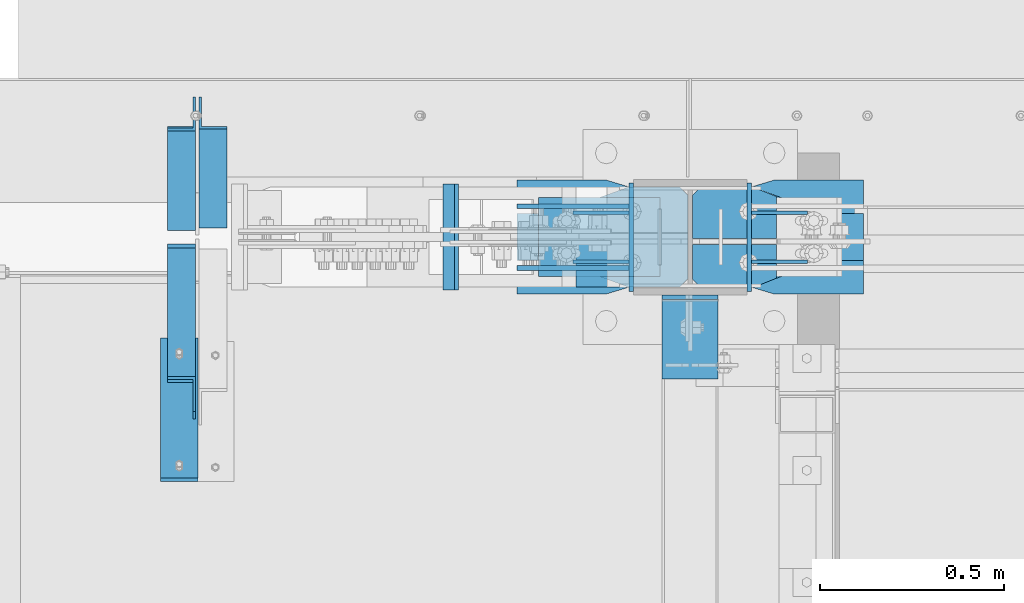
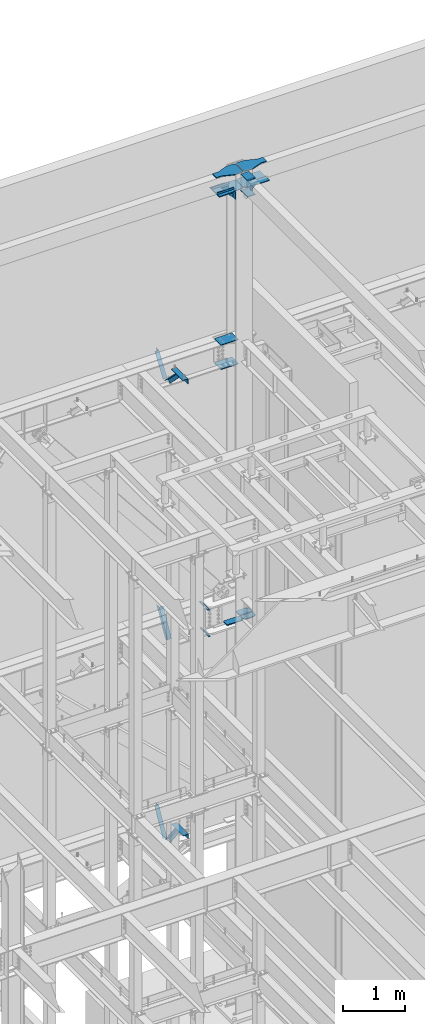
# One storey, part 926 of 1179: 23 beams, 5 members, 11 elements without a shape of their own.
"""IFC2X3 building model written with IfcOpenShell, lengths in millimetres."""

from ifc_helpers import new_model, si_unit, frame, origin_with_axes, place, context, subcontext, project, spatial, faceted_brep, material, type_object, element, aggregate, save


model = new_model("IFC2X3")

# Units and contexts
model_context = context("Model", 3, precision=1e-05, world=origin_with_axes())
body_context = subcontext(model_context, "Body", "Model", "MODEL_VIEW")
ifc_project = project(units=[si_unit("LENGTHUNIT", "METRE", prefix="MILLI"), si_unit("AREAUNIT", "SQUARE_METRE"), si_unit("VOLUMEUNIT", "CUBIC_METRE"), si_unit("MASSUNIT", "GRAM", prefix="KILO"), si_unit("TIMEUNIT", "SECOND"), si_unit("PLANEANGLEUNIT", "RADIAN"), si_unit("SOLIDANGLEUNIT", "STERADIAN"), si_unit("THERMODYNAMICTEMPERATUREUNIT", "DEGREE_CELSIUS"), si_unit("LUMINOUSINTENSITYUNIT", "LUMEN")], contexts=[model_context])

# Site, building, storey
site_placement = place(None, origin_with_axes())
site = spatial("IfcSite", under=ifc_project, at=site_placement, CompositionType="ELEMENT")
building_placement = place(site_placement, origin_with_axes())
building = spatial("IfcBuilding", under=site, at=building_placement, Name="Undefined", CompositionType="ELEMENT")
storey_placement = place(building_placement, origin_with_axes())
storey = spatial("IfcBuildingStorey", under=building, at=storey_placement, Name="Undefined", CompositionType="ELEMENT", Elevation=0.0)

# Assembly, member
assembly_1_placement = place(storey_placement, origin_with_axes())
assembly_1 = element("IfcElementAssembly", 1, at=assembly_1_placement, inside=storey, Name="ANGLE", AssemblyPlace="NOTDEFINED", PredefinedType="RIGID_FRAME")
ifc_material_1 = material(Name="STEEL/A36")
member_type = type_object("IfcMemberType", Name="L3X3X1/4", PredefinedType="NOTDEFINED")
member_1_placement = place(assembly_1_placement, frame((15160.625, 41656.0, 8227.31342088179), z_axis=(0.0, 0.872675718014636, -0.488300206008189), x_axis=(0.0, -0.48830020600819, -0.872675718014636)))
member_1 = element("IfcMember", 2, at=member_1_placement, type_object=member_type, material=ifc_material_1, Name="ANGLE", ObjectType="L3X3X1/4", context=body_context, shape_type="Brep", body=[
    faceted_brep([(266.09845322503, 38.1000000000004, -38.1000000001477), (223.461222774196, 38.1000000000004, 38.0999999997293), (818.212094408347, 38.1000000000004, 38.0999999992346), (818.21209440822, 38.1000000000004, -38.100000000617), (223.461222774196, 31.75, 38.0999999997293), (818.212094408347, 31.75, 38.0999999992346), (262.545350687458, 31.75, -31.7500000001601), (818.212094408227, 31.75, -31.7500000006257), (262.545350687458, -38.1000000000004, -31.7500000001601), (818.212094408227, -38.1000000000004, -31.7500000006257), (266.09845322503, -38.1000000000004, -38.1000000001477), (818.21209440822, -38.1000000000004, -38.100000000617)], [[[0, 1, 2, 3]], [[1, 4, 5, 2]], [[4, 6, 7, 5]], [[6, 8, 9, 7]], [[8, 10, 11, 9]], [[10, 0, 3, 11]], [[5, 7, 9, 11, 3, 2]], [[10, 8, 6, 4, 1, 0]]]),
])
aggregate(assembly_1, [member_1])

assembly_2_placement = place(storey_placement, origin_with_axes())
assembly_2 = element("IfcElementAssembly", 3, at=assembly_2_placement, inside=storey, Name="ANGLE", AssemblyPlace="NOTDEFINED", PredefinedType="RIGID_FRAME")
member_2_placement = place(assembly_2_placement, frame((15074.90025, 40722.5021746856, 4156.39103856133), z_axis=(0.0, -0.797785167426298, -0.602941810322185), x_axis=(0.0, 0.602941810322187, -0.797785167426297)))
member_2 = element("IfcMember", 4, at=member_2_placement, type_object=member_type, material=ifc_material_1, Name="ANGLE", ObjectType="L3X3X1/4", context=body_context, shape_type="Brep", body=[
    faceted_brep([(110.776215380578, 38.1000000000004, -38.1000000000058), (53.1865686658894, 38.1000000000004, 38.1000000001659), (690.351875241478, 38.1000000000004, 38.1000000007261), (690.351875241598, 38.1000000000004, -38.0999999994892), (53.1865686658894, 31.75, 38.1000000001659), (690.351875241478, 31.75, 38.1000000007261), (105.977078154352, 31.75, -31.7499999999927), (690.351875241595, 31.75, -31.7499999994689), (105.977078154352, -38.1000000000004, -31.7499999999927), (690.351875241595, -38.1000000000004, -31.7499999994689), (110.776215380578, -38.1000000000004, -38.1000000000058), (690.351875241598, -38.1000000000004, -38.0999999994892)], [[[0, 1, 2, 3]], [[1, 4, 5, 2]], [[4, 6, 7, 5]], [[6, 8, 9, 7]], [[8, 10, 11, 9]], [[10, 0, 3, 11]], [[5, 7, 9, 11, 3, 2]], [[10, 8, 6, 4, 1, 0]]]),
])
aggregate(assembly_2, [member_2])

assembly_3_placement = place(storey_placement, origin_with_axes())
assembly_3 = element("IfcElementAssembly", 5, at=assembly_3_placement, inside=storey, Name="ANGLE", AssemblyPlace="NOTDEFINED", PredefinedType="RIGID_FRAME")
member_3_placement = place(assembly_3_placement, frame((15074.90025, 41256.8364339201, 3601.33927004389), z_axis=(0.0, 0.873306509536275, -0.487171161299155), x_axis=(0.0, 0.487171161299156, 0.873306509536275)))
member_3 = element("IfcMember", 6, at=member_3_placement, type_object=member_type, material=ifc_material_1, Name="ANGLE", ObjectType="L3X3X1/4", context=body_context, shape_type="Brep", body=[
    faceted_brep([(0.0, 38.0999999999985, -38.0999999999999), (0.0, 38.0999999999985, 38.0999999999999), (594.661720177039, 38.1000000000004, 38.1000000011991), (552.153801037723, 38.1000000000004, -38.0999999989144), (0.0, 31.75, 38.1000000000004), (594.661720177039, 31.75, 38.1000000011991), (0.0, 31.75, -31.75), (555.696127632669, 31.75, -31.7499999988941), (0.0, -38.0999999999985, -31.75), (555.696127632669, -38.1000000000004, -31.7499999988941), (0.0, -38.0999999999985, -38.0999999999999), (552.153801037723, -38.1000000000004, -38.0999999989144)], [[[0, 1, 2, 3]], [[1, 4, 5, 2]], [[4, 6, 7, 5]], [[6, 8, 9, 7]], [[8, 10, 11, 9]], [[10, 0, 3, 11]], [[5, 7, 9, 11, 3, 2]], [[10, 8, 6, 4, 1, 0]]]),
])
aggregate(assembly_3, [member_3])

assembly_4_placement = place(storey_placement, origin_with_axes())
assembly_4 = element("IfcElementAssembly", 7, at=assembly_4_placement, inside=storey, Name="ANGLE", AssemblyPlace="NOTDEFINED", PredefinedType="RIGID_FRAME")
member_4_placement = place(assembly_4_placement, frame((15074.9, 40704.7386537875, 13150.1502196524), z_axis=(0.0, -0.706388288025418, -0.707824545025474), x_axis=(0.0, 0.707824545025473, -0.706388288025419)))
member_4 = element("IfcMember", 8, at=member_4_placement, type_object=member_type, material=ifc_material_1, Name="ANGLE", ObjectType="L3X3X1/4", context=body_context, shape_type="Brep", body=[
    faceted_brep([(634.184990526992, 31.75, 38.0999999999767), (634.184990526996, 31.75, -31.7499999999636), (634.184990526996, -38.0999999999985, -31.7499999999636), (634.184990526996, -38.0999999999985, -38.0999999999549), (634.184990526996, 38.0999999999985, -38.0999999999549), (634.184990526992, 38.0999999999985, 38.0999999999767), (113.596638248473, -38.0999999999985, -38.0999999999549), (113.596638248473, 38.0999999999985, -38.0999999999549), (37.2417053522113, 38.0999999999985, 38.0999999999694), (37.2417053522113, 31.75, 38.0999999999694), (107.233727173789, 31.75, -31.7499999999709), (107.233727173789, -38.0999999999985, -31.7499999999709)], [[[0, 1, 2, 3, 4, 5]], [[4, 3, 6, 7]], [[5, 4, 7, 8]], [[0, 5, 8, 9]], [[1, 0, 9, 10]], [[2, 1, 10, 11]], [[3, 2, 11, 6]], [[10, 9, 8, 7, 6, 11]]]),
])
aggregate(assembly_4, [member_4])

assembly_5_placement = place(storey_placement, origin_with_axes())
assembly_5 = element("IfcElementAssembly", 9, at=assembly_5_placement, inside=storey, Name="ANGLE", AssemblyPlace="NOTDEFINED", PredefinedType="RIGID_FRAME")
member_5_placement = place(assembly_5_placement, frame((15074.9, 41248.3636551321, 12707.4244380128), z_axis=(0.0, 0.821716663099518, -0.569896241069015), x_axis=(0.0, 0.569896241069016, 0.821716663099518)))
member_5 = element("IfcMember", 10, at=member_5_placement, type_object=member_type, material=ifc_material_1, Name="ANGLE", ObjectType="L3X3X1/4", context=body_context, shape_type="Brep", body=[
    faceted_brep([(0.0, -38.0999999999985, -38.0999999999999), (0.0, -38.0999999999985, -31.75), (0.0, 31.75, -31.75), (0.0, 31.75, 38.1000000000004), (0.0, 38.0999999999985, 38.0999999999999), (0.0, 38.0999999999985, -38.0999999999999), (527.418547333735, 31.75, 38.0999999993364), (527.418547333735, 38.1000000000004, 38.0999999993364), (474.570533511644, 38.1000000000004, -38.1000000006607), (474.570533511644, -38.1000000000004, -38.1000000006607), (478.974534663488, -38.1000000000004, -31.7500000006621), (478.974534663488, 31.75, -31.7500000006621)], [[[0, 1, 2, 3, 4, 5]], [[4, 3, 6, 7]], [[5, 4, 7, 8]], [[0, 5, 8, 9]], [[1, 0, 9, 10]], [[2, 1, 10, 11]], [[3, 2, 11, 6]], [[10, 9, 8, 7, 6, 11]]]),
])
aggregate(assembly_5, [member_5])

# Assembly, beams
assembly_6_placement = place(storey_placement, origin_with_axes())
assembly_6 = element("IfcElementAssembly", 11, at=assembly_6_placement, inside=storey, Name="BEAM", AssemblyPlace="NOTDEFINED", PredefinedType="RIGID_FRAME")
ifc_material_2 = material(Name="STEEL/A572-GR.50")
beam_type_1 = type_object("IfcBeamType", PredefinedType="NOTDEFINED")
beam_1_placement = place(assembly_6_placement, frame((15828.6656815561, 41198.7999633791, 7459.6625), z_axis=(0.0, 1.0, 0.0), x_axis=(-1.0, 0.0, 0.0)))
beam_1 = element("IfcBeam", 12, at=beam_1_placement, type_object=beam_type_1, material=ifc_material_2, Name="PLATE", context=body_context, shape_type="Brep", body=[
    faceted_brep([(0.0, 4.76249999999982, -144.462500000001), (0.0, 4.76249999999982, 144.462500000001), (31.7500000000036, 4.76249999999982, 144.462500000001), (31.7500000000036, 4.76249999999982, -144.462500000001), (0.0, -4.76249999999982, 144.462500000001), (31.7500000000036, -4.76249999999982, 144.462500000001), (0.0, -4.76249999999982, -144.462500000001), (31.7500000000036, -4.76249999999982, -144.462500000001)], [[[0, 1, 2, 3]], [[1, 4, 5, 2]], [[4, 6, 7, 5]], [[6, 0, 3, 7]], [[5, 7, 3, 2]], [[6, 4, 1, 0]]]),
])
beam_2_placement = place(assembly_6_placement, frame((15817.5535981227, 41198.7999633791, 7984.72549025941), z_axis=(0.0, 1.0, 0.0), x_axis=(-1.0, 0.0, 0.0)))
beam_2 = element("IfcBeam", 13, at=beam_2_placement, type_object=beam_type_1, material=ifc_material_2, Name="PLATE", context=body_context, shape_type="Brep", body=[
    faceted_brep([(0.0, 4.76249999999982, -144.462500000001), (0.0, 4.76249999999982, 144.462500000001), (31.7500000000036, 4.76249999999982, 144.462500000001), (31.7500000000036, 4.76249999999982, -144.462500000001), (0.0, -4.76249999999982, 144.462500000001), (31.7500000000036, -4.76249999999982, 144.462500000001), (0.0, -4.76249999999982, -144.462500000001), (31.7500000000036, -4.76249999999982, -144.462500000001)], [[[0, 1, 2, 3]], [[1, 4, 5, 2]], [[4, 6, 7, 5]], [[6, 0, 3, 7]], [[5, 7, 3, 2]], [[6, 4, 1, 0]]]),
])
aggregate(assembly_6, [beam_1, beam_2])

assembly_7_placement = place(storey_placement, origin_with_axes())
assembly_7 = element("IfcElementAssembly", 14, at=assembly_7_placement, inside=storey, Name="COLUMN", AssemblyPlace="NOTDEFINED", PredefinedType="RIGID_FRAME")
beam_type_2 = type_object("IfcBeamType", PredefinedType="NOTDEFINED")
beam_3_placement = place(assembly_7_placement, frame((16298.8624999594, 41346.4375, 16030.575), z_axis=(0.0, 0.0, 1.0), x_axis=(0.0, -1.0, 0.0)))
beam_3 = element("IfcBeam", 15, at=beam_3_placement, type_object=beam_type_2, material=ifc_material_1, Name="PLATE", context=body_context, shape_type="Brep", body=[
    faceted_brep([(-7.27595761418343e-12, 6.35000000000036, -76.1999999999971), (0.0, 6.35000000000036, 76.2000000000044), (295.274999999994, 6.34999999999854, 76.2000000000007), (295.274999999994, 6.34999999999854, -76.2000000000007), (0.0, -6.35000000000036, 76.2000000000044), (295.274999999994, -6.34999999999854, 76.2000000000007), (7.27595761418343e-12, -6.35000000000036, -76.1999999999971), (295.274999999994, -6.34999999999854, -76.2000000000007)], [[[0, 1, 2, 3]], [[1, 4, 5, 2]], [[4, 6, 7, 5]], [[6, 0, 3, 7]], [[5, 7, 3, 2]], [[6, 4, 1, 0]]]),
])
beam_4_placement = place(assembly_7_placement, frame((16619.5375, 41051.1625, 16030.575), z_axis=(0.0, 0.0, 1.0), x_axis=(0.0, 1.0, 0.0)))
beam_4 = element("IfcBeam", 16, at=beam_4_placement, type_object=beam_type_2, material=ifc_material_1, Name="PLATE", context=body_context, shape_type="Brep", body=[
    faceted_brep([(-7.27595761418343e-12, 6.35000000000036, -76.1999999999971), (0.0, 6.35000000000036, 76.2000000000044), (295.274999999994, 6.34999999999854, 76.2000000000007), (295.274999999994, 6.34999999999854, -76.2000000000007), (0.0, -6.35000000000036, 76.2000000000044), (295.274999999994, -6.34999999999854, 76.2000000000007), (7.27595761418343e-12, -6.35000000000036, -76.1999999999971), (295.274999999994, -6.34999999999854, -76.2000000000007)], [[[0, 1, 2, 3]], [[1, 4, 5, 2]], [[4, 6, 7, 5]], [[6, 0, 3, 7]], [[5, 7, 3, 2]], [[6, 4, 1, 0]]]),
])
beam_5_placement = place(assembly_7_placement, frame((16459.2, 40813.0375061035, 16116.3), z_axis=(1.0, 0.0, 0.0), x_axis=(0.0, 1.0, 0.0)))
beam_5 = element("IfcBeam", 17, at=beam_5_placement, type_object=beam_type_2, material=ifc_material_1, Name="PLATE", context=body_context, shape_type="Brep", body=[
    faceted_brep([(215.900000000001, 6.35000000000036, 76.2000000000007), (228.599999999999, -6.35000000000036, 76.2000000000007), (228.599999999999, -6.35000000000036, -76.2000000000007), (215.900000000001, 6.35000000000036, -76.2000000000007), (-7.27595761418343e-12, 6.35000000000036, -76.1999999999971), (0.0, 6.35000000000036, 76.2000000000044), (0.0, -6.35000000000036, 76.2000000000044), (7.27595761418343e-12, -6.35000000000036, -76.1999999999971)], [[[0, 1, 2, 3]], [[4, 5, 0, 3]], [[5, 6, 1, 0]], [[6, 7, 2, 1]], [[7, 4, 3, 2]], [[7, 6, 5, 4]]]),
])
beam_6_placement = place(assembly_7_placement, frame((16459.2, 40813.0375059853, 16435.3875), z_axis=(1.0, 0.0, 0.0), x_axis=(0.0, 1.0, 0.0)))
beam_6 = element("IfcBeam", 18, at=beam_6_placement, type_object=beam_type_2, material=ifc_material_1, Name="PLATE", context=body_context, shape_type="Brep", body=[
    faceted_brep([(215.900000000001, 6.35000000000036, 76.2000000000007), (228.599999999999, -6.35000000000036, 76.2000000000007), (228.599999999999, -6.35000000000036, -76.2000000000007), (215.900000000001, 6.35000000000036, -76.2000000000007), (-7.27595761418343e-12, 6.35000000000036, -76.1999999999971), (0.0, 6.35000000000036, 76.2000000000044), (0.0, -6.35000000000036, 76.2000000000044), (7.27595761418343e-12, -6.35000000000036, -76.1999999999971)], [[[0, 1, 2, 3]], [[4, 5, 0, 3]], [[5, 6, 1, 0]], [[6, 7, 2, 1]], [[7, 4, 3, 2]], [[7, 6, 5, 4]]]),
])
beam_type_3 = type_object("IfcBeamType", PredefinedType="NOTDEFINED")
beam_7_placement = place(assembly_7_placement, frame((16376.8467347126, 41198.8000000024, 12646.02499997), z_axis=(0.0, -1.0, 0.0), x_axis=(-1.0, 0.0, 0.0)))
beam_7 = element("IfcBeam", 19, at=beam_7_placement, type_object=beam_type_3, material=ifc_material_2, Name="PLATE", context=body_context, shape_type="Brep", body=[
    faceted_brep([(0.0, 6.35000000000036, -107.949999999997), (0.0, 6.35000000000036, 107.949999999997), (330.200000043667, 6.35000000000036, 107.949999999997), (330.200000043667, 6.35000000000036, -107.949999999997), (0.0, -6.35000000000036, 107.949999999997), (330.200000043667, -6.35000000000036, 107.949999999997), (0.0, -6.35000000000036, -107.949999999997), (330.200000043667, -6.35000000000036, -107.949999999997)], [[[0, 1, 2, 3]], [[1, 4, 5, 2]], [[4, 6, 7, 5]], [[6, 0, 3, 7]], [[5, 7, 3, 2]], [[6, 4, 1, 0]]]),
])
beam_8_placement = place(assembly_7_placement, frame((16376.8467347052, 41198.8000000024, 13125.44999997), z_axis=(0.0, -1.0, 0.0), x_axis=(-1.0, 0.0, 0.0)))
beam_8 = element("IfcBeam", 20, at=beam_8_placement, type_object=beam_type_3, material=ifc_material_2, Name="PLATE", context=body_context, shape_type="Brep", body=[
    faceted_brep([(0.0, 6.35000000000036, -107.949999999997), (0.0, 6.35000000000036, 107.949999999997), (330.200000043667, 6.35000000000036, 107.949999999997), (330.200000043667, 6.35000000000036, -107.949999999997), (0.0, -6.35000000000036, 107.949999999997), (330.200000043667, -6.35000000000036, 107.949999999997), (0.0, -6.35000000000036, -107.949999999997), (330.200000043667, -6.35000000000036, -107.949999999997)], [[[0, 1, 2, 3]], [[1, 4, 5, 2]], [[4, 6, 7, 5]], [[6, 0, 3, 7]], [[5, 7, 3, 2]], [[6, 4, 1, 0]]]),
])
beam_type_4 = type_object("IfcBeamType", PredefinedType="NOTDEFINED")
beam_9_placement = place(assembly_7_placement, frame((16148.0499999994, 41125.775, 7556.5), z_axis=(0.0, -1.0, 0.0), x_axis=(1.0, 0.0, 0.0)))
beam_9 = element("IfcBeam", 21, at=beam_9_placement, type_object=beam_type_4, material=ifc_material_2, Name="PLATE", context=body_context, shape_type="Brep", body=[
    faceted_brep([(304.800000000001, 9.52499999999964, 41.2750000000015), (282.575000000003, 9.52499999999964, 63.5), (282.575000000003, -9.52499999999964, 63.5), (304.800000000001, -9.52499999999964, 41.2750000000015), (304.800000000001, 9.52499999999964, -63.5), (0.0, 9.52500000000146, -63.5), (0.0, 9.52500000000146, 63.5), (0.0, -9.52500000000146, 63.5), (0.0, -9.52500000000146, -63.5), (304.800000000001, -9.52499999999964, -63.5)], [[[0, 1, 2, 3]], [[4, 5, 6, 1, 0]], [[6, 7, 2, 1]], [[7, 8, 9, 3, 2]], [[8, 5, 4, 9]], [[9, 4, 0, 3]], [[8, 7, 6, 5]]]),
])

# Assembly, beam
assembly_8_placement = place(storey_placement, origin_with_axes())
assembly_8 = element("IfcElementAssembly", 22, at=assembly_8_placement, inside=storey, Name="ANGLE", AssemblyPlace="NOTDEFINED", PredefinedType="RIGID_FRAME")
beam_type_5 = type_object("IfcBeamType", Name="L4X4X1/4", PredefinedType="NOTDEFINED")
beam_10_placement = place(assembly_8_placement, frame((15068.5502499985, 40914.6373750007, 4051.30000000071), z_axis=(-1.0, 0.0, 0.0), x_axis=(0.0, -1.0, 0.0)))
beam_10 = element("IfcBeam", 23, at=beam_10_placement, type_object=beam_type_5, material=ifc_material_1, Name="ANGLE", ObjectType="L4X4X1/4", context=body_context, shape_type="Brep", body=[
    faceted_brep([(1.90993887372315e-11, 50.8000000000002, -50.8000000000002), (1.90993887372315e-11, 50.8000000000002, 50.8000000000002), (381.0, 50.8000000000002, 50.7999999999993), (381.0, 50.8000000000002, -50.7999999999993), (0.0, 44.4500000000007, 50.8000000000002), (381.0, 44.4499999999998, 50.7999999999993), (0.0, 44.4500000000007, -44.4499999999998), (381.0, 44.4499999999998, -44.4500000000007), (0.0, -50.7999999999993, -44.4499999999998), (381.0, -50.8000000000002, -44.4500000000007), (-1.81898940354586e-11, -50.7999999999997, -50.8000000000002), (381.0, -50.8000000000002, -50.7999999999993)], [[[0, 1, 2, 3]], [[1, 4, 5, 2]], [[4, 6, 7, 5]], [[6, 8, 9, 7]], [[8, 10, 11, 9]], [[10, 0, 3, 11]], [[5, 7, 9, 11, 3, 2]], [[10, 8, 6, 4, 1, 0]]]),
])
aggregate(assembly_8, [beam_10])

assembly_9_placement = place(storey_placement, origin_with_axes())
assembly_9 = element("IfcElementAssembly", 24, at=assembly_9_placement, inside=storey, Name="ANGLE", AssemblyPlace="NOTDEFINED", PredefinedType="RIGID_FRAME")
beam_11_placement = place(assembly_9_placement, frame((15068.549999998, 40924.1624999531, 13068.3), z_axis=(-1.0, 0.0, 0.0), x_axis=(0.0, -1.0, 0.0)))
beam_11 = element("IfcBeam", 25, at=beam_11_placement, type_object=beam_type_5, material=ifc_material_1, Name="ANGLE", ObjectType="L4X4X1/4", context=body_context, shape_type="Brep", body=[
    faceted_brep([(1.90993887372315e-11, 50.8000000000002, -50.8000000000002), (1.90993887372315e-11, 50.8000000000002, 50.8000000000002), (381.0, 50.8000000000002, 50.7999999999993), (381.0, 50.8000000000002, -50.7999999999993), (0.0, 44.4500000000007, 50.8000000000002), (381.0, 44.4499999999998, 50.7999999999993), (0.0, 44.4500000000007, -44.4499999999998), (381.0, 44.4499999999998, -44.4500000000007), (0.0, -50.7999999999993, -44.4499999999998), (381.0, -50.8000000000002, -44.4500000000007), (-1.81898940354586e-11, -50.7999999999997, -50.8000000000002), (381.0, -50.8000000000002, -50.7999999999993)], [[[0, 1, 2, 3]], [[1, 4, 5, 2]], [[4, 6, 7, 5]], [[6, 8, 9, 7]], [[8, 10, 11, 9]], [[10, 0, 3, 11]], [[5, 7, 9, 11, 3, 2]], [[10, 8, 6, 4, 1, 0]]]),
])
aggregate(assembly_9, [beam_11])

# Beam
beam_type_6 = type_object("IfcBeamType", PredefinedType="NOTDEFINED")
beam_12_placement = place(assembly_7_placement, frame((15987.7124999797, 41282.9375, 16141.7), z_axis=(0.0, 0.0, 1.0), x_axis=(1.0, 0.0, 0.0)))
beam_12 = element("IfcBeam", 26, at=beam_12_placement, type_object=beam_type_6, material=ifc_material_1, Name="PLATE", context=body_context, shape_type="Brep", body=[
    faceted_brep([(0.0, 6.34999999999854, -19.0499999999993), (0.0, 6.35000000000036, 19.0499999999993), (317.5, 6.34999999999854, 19.0499999999993), (317.5, 6.34999999999854, -19.0499999999993), (0.0, -6.35000000000036, 19.0499999999993), (317.5, -6.34999999999854, 19.0499999999993), (0.0, -6.34999999999854, -19.0499999999993), (317.5, -6.34999999999854, -19.0499999999993)], [[[0, 1, 2, 3]], [[1, 4, 5, 2]], [[4, 6, 7, 5]], [[6, 0, 3, 7]], [[5, 7, 3, 2]], [[6, 4, 1, 0]]]),
])

beam_13_placement = place(assembly_7_placement, frame((15987.7124999797, 41114.6625, 16141.7), z_axis=(0.0, 0.0, 1.0), x_axis=(1.0, 0.0, 0.0)))
beam_13 = element("IfcBeam", 27, at=beam_13_placement, type_object=beam_type_6, material=ifc_material_1, Name="PLATE", context=body_context, shape_type="Brep", body=[
    faceted_brep([(0.0, 6.34999999999854, -19.0499999999993), (0.0, 6.35000000000036, 19.0499999999993), (317.5, 6.34999999999854, 19.0499999999993), (317.5, 6.34999999999854, -19.0499999999993), (0.0, -6.35000000000036, 19.0499999999993), (317.5, -6.34999999999854, 19.0499999999993), (0.0, -6.34999999999854, -19.0499999999993), (317.5, -6.34999999999854, -19.0499999999993)], [[[0, 1, 2, 3]], [[1, 4, 5, 2]], [[4, 6, 7, 5]], [[6, 0, 3, 7]], [[5, 7, 3, 2]], [[6, 4, 1, 0]]]),
])

beam_type_7 = type_object("IfcBeamType", PredefinedType="NOTDEFINED")
beam_14_placement = place(assembly_7_placement, frame((16140.1124999594, 41265.475, 16030.575), z_axis=(0.0, 0.0, 1.0), x_axis=(1.0, 0.0, 0.0)))
beam_14 = element("IfcBeam", 28, at=beam_14_placement, type_object=beam_type_7, material=ifc_material_1, Name="PLATE", context=body_context, shape_type="Brep", body=[
    faceted_brep([(152.4, -4.76249999999709, 76.2), (152.4, -4.76249999999709, -76.2), (152.4, 4.76249999999709, -76.2), (152.4, 4.76249999999709, 76.2), (0.0, 4.76249999999982, 76.1999999999971), (0.0, -4.76249999999982, 76.1999999999971)], [[[0, 1, 2, 3]], [[3, 2, 4]], [[4, 5, 0, 3]], [[0, 5, 1]], [[4, 2, 1, 5]]]),
])

beam_15_placement = place(assembly_7_placement, frame((16140.1124999594, 41132.125, 16030.575), z_axis=(0.0, 0.0, 1.0), x_axis=(1.0, 0.0, 0.0)))
beam_15 = element("IfcBeam", 29, at=beam_15_placement, type_object=beam_type_7, material=ifc_material_1, Name="PLATE", context=body_context, shape_type="Brep", body=[
    faceted_brep([(152.4, -4.76249999999709, 76.2), (152.4, -4.76249999999709, -76.2), (152.4, 4.76249999999709, -76.2), (152.4, 4.76249999999709, 76.2), (0.0, 4.76249999999982, 76.1999999999971), (0.0, -4.76249999999982, 76.1999999999971)], [[[0, 1, 2, 3]], [[3, 2, 4]], [[4, 5, 0, 3]], [[0, 5, 1]], [[4, 2, 1, 5]]]),
])

beam_16_placement = place(assembly_7_placement, frame((16778.2875, 41132.125, 16030.575), z_axis=(0.0, 0.0, 1.0), x_axis=(-1.0, 0.0, 0.0)))
beam_16 = element("IfcBeam", 30, at=beam_16_placement, type_object=beam_type_7, material=ifc_material_1, Name="PLATE", context=body_context, shape_type="Brep", body=[
    faceted_brep([(152.4, -4.76249999999709, 76.2), (152.4, -4.76249999999709, -76.2), (152.4, 4.76249999999709, -76.2), (152.4, 4.76249999999709, 76.2), (0.0, 4.76249999999982, 76.1999999999971), (0.0, -4.76249999999982, 76.1999999999971)], [[[0, 1, 2, 3]], [[3, 2, 4]], [[4, 5, 0, 3]], [[0, 5, 1]], [[4, 2, 1, 5]]]),
])

beam_17_placement = place(assembly_7_placement, frame((16778.2875, 41265.475, 16030.575), z_axis=(0.0, 0.0, 1.0), x_axis=(-1.0, 0.0, 0.0)))
beam_17 = element("IfcBeam", 31, at=beam_17_placement, type_object=beam_type_7, material=ifc_material_1, Name="PLATE", context=body_context, shape_type="Brep", body=[
    faceted_brep([(152.4, -4.76249999999709, 76.2), (152.4, -4.76249999999709, -76.2), (152.4, 4.76249999999709, -76.2), (152.4, 4.76249999999709, 76.2), (0.0, 4.76249999999982, 76.1999999999971), (0.0, -4.76249999999982, 76.1999999999971)], [[[0, 1, 2, 3]], [[3, 2, 4]], [[4, 5, 0, 3]], [[0, 5, 1]], [[4, 2, 1, 5]]]),
])

beam_type_8 = type_object("IfcBeamType", PredefinedType="NOTDEFINED")
beam_18_placement = place(assembly_7_placement, frame((15987.7124999594, 41198.8, 16114.7125), z_axis=(0.0, -1.0, 0.0), x_axis=(1.0, 0.0, 0.0)))
beam_18 = element("IfcBeam", 32, at=beam_18_placement, type_object=beam_type_8, material=ifc_material_1, Name="PLATE", context=body_context, shape_type="Brep", body=[
    faceted_brep([(465.137499999997, -7.9375, -114.300000762945), (442.912499999999, -7.9375, -136.525000762944), (442.912500000006, 7.9375, -136.525000762944), (465.137500000004, 7.9375, -114.300000762945), (465.137500000004, 7.9375, 114.300000762938), (442.912500000006, 7.9375, 136.525000762937), (442.912499999999, -7.9375, 136.525000762937), (465.137499999997, -7.9375, 114.300000762938), (241.300006103491, -7.9375, -155.575000000001), (241.300006103491, 7.9375, -155.575000000001), (304.799990844724, 7.9375, -136.525000762944), (304.799990844724, -7.9375, -136.525000762944), (0.0, -7.9375, -155.575000000001), (0.0, -7.9375, 155.575000000001), (0.0, 7.9375, 155.575000000001), (0.0, 7.9375, -155.575000000001), (241.300006103513, -7.9375, 155.575000000001), (241.300006103513, 7.9375, 155.575000000001), (304.799990844724, -7.9375, 136.525000762937), (304.799990844724, 7.9375, 136.525000762937)], [[[0, 1, 2, 3]], [[4, 5, 6, 7]], [[8, 9, 10, 11]], [[11, 10, 2, 1]], [[12, 13, 14, 15]], [[14, 13, 16, 17]], [[18, 19, 17, 16]], [[19, 18, 6, 5]], [[4, 7, 0, 3]], [[10, 9, 15, 14, 17, 19, 5, 4, 3, 2]], [[12, 15, 9, 8]], [[7, 6, 18, 16, 13, 12, 8, 11, 1, 0]]]),
])

beam_19_placement = place(assembly_7_placement, frame((16930.6875, 41198.8, 16114.7125), z_axis=(0.0, 1.0, 0.0), x_axis=(-1.0, 0.0, 0.0)))
beam_19 = element("IfcBeam", 33, at=beam_19_placement, type_object=beam_type_8, material=ifc_material_1, Name="PLATE", context=body_context, shape_type="Brep", body=[
    faceted_brep([(465.137499999997, -7.9375, -114.300000762945), (442.912499999999, -7.9375, -136.525000762944), (442.912500000006, 7.9375, -136.525000762944), (465.137500000004, 7.9375, -114.300000762945), (465.137500000004, 7.9375, 114.300000762938), (442.912500000006, 7.9375, 136.525000762937), (442.912499999999, -7.9375, 136.525000762937), (465.137499999997, -7.9375, 114.300000762938), (241.300006103491, -7.9375, -155.575000000001), (241.300006103491, 7.9375, -155.575000000001), (304.799990844724, 7.9375, -136.525000762944), (304.799990844724, -7.9375, -136.525000762944), (0.0, -7.9375, -155.575000000001), (0.0, -7.9375, 155.575000000001), (0.0, 7.9375, 155.575000000001), (0.0, 7.9375, -155.575000000001), (241.300006103513, -7.9375, 155.575000000001), (241.300006103513, 7.9375, 155.575000000001), (304.799990844724, -7.9375, 136.525000762937), (304.799990844724, 7.9375, 136.525000762937)], [[[0, 1, 2, 3]], [[4, 5, 6, 7]], [[8, 9, 10, 11]], [[11, 10, 2, 1]], [[12, 13, 14, 15]], [[14, 13, 16, 17]], [[18, 19, 17, 16]], [[19, 18, 6, 5]], [[4, 7, 0, 3]], [[10, 9, 15, 14, 17, 19, 5, 4, 3, 2]], [[12, 15, 9, 8]], [[7, 6, 18, 16, 13, 12, 8, 11, 1, 0]]]),
])

# Assembly, beam
assembly_10_placement = place(storey_placement, origin_with_axes())
assembly_10 = element("IfcElementAssembly", 34, at=assembly_10_placement, inside=storey, Name="PLATE", AssemblyPlace="NOTDEFINED", PredefinedType="RIGID_FRAME")
beam_type_9 = type_object("IfcBeamType", PredefinedType="NOTDEFINED")
beam_20_placement = place(assembly_10_placement, frame((15987.7124999594, 41198.8, 16435.3875), z_axis=(0.0, -1.0, 0.0), x_axis=(1.0, 0.0, 0.0)))
beam_20 = element("IfcBeam", 35, at=beam_20_placement, type_object=beam_type_9, material=ifc_material_1, Name="PLATE", context=body_context, shape_type="Brep", body=[
    faceted_brep([(465.137499999997, -7.9375, -114.300000762945), (442.912499999999, -7.9375, -136.525000762944), (442.912500000006, 7.9375, -136.525000762944), (465.137500000004, 7.9375, -114.300000762945), (465.137500000004, 7.9375, 114.300000762938), (442.912500000006, 7.9375, 136.525000762937), (442.912499999999, -7.9375, 136.525000762937), (465.137499999997, -7.9375, 114.300000762938), (97.1744871646697, -7.9375, 63.4999984741225), (97.1744871646697, 7.9375, 63.4999984741225), (0.0, 7.9375, 63.5), (0.0, -7.9375, 63.5), (99.3625358760146, -7.9375, 63.5944172169256), (99.3625358760146, 7.9375, 63.5944172169256), (101.534317436837, -7.9375, 63.8769714847585), (101.534317436837, 7.9375, 63.8769714847585), (103.673685635511, -7.9375, 64.3455606147181), (103.673685635511, 7.9375, 64.3455606147181), (105.764735239063, -7.9375, 64.9967008589738), (105.764735239063, 7.9375, 64.9967008589738), (304.799990844724, -7.9375, 136.525000762937), (304.799990844724, 7.9375, 136.525000762937), (0.0, -7.9375, -63.5), (0.0, 7.9375, -63.5), (97.1744871646697, 7.9375, -63.5), (97.1744871646697, -7.9375, -63.5), (99.3625358760146, 7.9375, -63.5944187428031), (99.3625358760146, -7.9375, -63.5944187428031), (101.534317436837, 7.9375, -63.876973010636), (101.534317436837, -7.9375, -63.876973010636), (103.673685635511, 7.9375, -64.3455621405956), (103.673685635511, -7.9375, -64.3455621405956), (105.764735239063, 7.9375, -64.9967023848512), (105.764735239063, -7.9375, -64.9967023848512), (304.799990844724, -7.9375, -136.525000762944), (304.799990844724, 7.9375, -136.525000762944)], [[[0, 1, 2, 3]], [[4, 5, 6, 7]], [[8, 9, 10, 11]], [[12, 13, 9, 8]], [[14, 15, 13, 12]], [[16, 17, 15, 14]], [[18, 19, 17, 16]], [[20, 21, 19, 18]], [[22, 23, 24, 25]], [[25, 24, 26, 27]], [[27, 26, 28, 29]], [[29, 28, 30, 31]], [[31, 30, 32, 33]], [[34, 33, 32, 35]], [[34, 35, 2, 1]], [[4, 7, 0, 3]], [[7, 6, 20, 18, 16, 14, 12, 8, 11, 22, 25, 27, 29, 31, 33, 34, 1, 0]], [[22, 11, 10, 23]], [[35, 32, 30, 28, 26, 24, 23, 10, 9, 13, 15, 17, 19, 21, 5, 4, 3, 2]], [[21, 20, 6, 5]]]),
])
aggregate(assembly_10, [beam_20])

assembly_11_placement = place(storey_placement, origin_with_axes())
assembly_11 = element("IfcElementAssembly", 36, at=assembly_11_placement, inside=storey, Name="PLATE", AssemblyPlace="NOTDEFINED", PredefinedType="RIGID_FRAME")
beam_21_placement = place(assembly_11_placement, frame((16930.6875, 41198.8, 16435.3875), z_axis=(0.0, 1.0, 0.0), x_axis=(-1.0, 0.0, 0.0)))
beam_21 = element("IfcBeam", 37, at=beam_21_placement, type_object=beam_type_9, material=ifc_material_1, Name="PLATE", context=body_context, shape_type="Brep", body=[
    faceted_brep([(465.137499999997, -7.9375, -114.300000762945), (442.912499999999, -7.9375, -136.525000762944), (442.912500000006, 7.9375, -136.525000762944), (465.137500000004, 7.9375, -114.300000762945), (465.137500000004, 7.9375, 114.300000762938), (442.912500000006, 7.9375, 136.525000762937), (442.912499999999, -7.9375, 136.525000762937), (465.137499999997, -7.9375, 114.300000762938), (97.1744871646697, -7.9375, 63.4999984741225), (97.1744871646697, 7.9375, 63.4999984741225), (0.0, 7.9375, 63.5), (0.0, -7.9375, 63.5), (99.3625358760146, -7.9375, 63.5944172169256), (99.3625358760146, 7.9375, 63.5944172169256), (101.534317436837, -7.9375, 63.8769714847585), (101.534317436837, 7.9375, 63.8769714847585), (103.673685635511, -7.9375, 64.3455606147181), (103.673685635511, 7.9375, 64.3455606147181), (105.764735239063, -7.9375, 64.9967008589738), (105.764735239063, 7.9375, 64.9967008589738), (304.799990844724, -7.9375, 136.525000762937), (304.799990844724, 7.9375, 136.525000762937), (0.0, -7.9375, -63.5), (0.0, 7.9375, -63.5), (97.1744871646697, 7.9375, -63.5), (97.1744871646697, -7.9375, -63.5), (99.3625358760146, 7.9375, -63.5944187428031), (99.3625358760146, -7.9375, -63.5944187428031), (101.534317436837, 7.9375, -63.876973010636), (101.534317436837, -7.9375, -63.876973010636), (103.673685635511, 7.9375, -64.3455621405956), (103.673685635511, -7.9375, -64.3455621405956), (105.764735239063, 7.9375, -64.9967023848512), (105.764735239063, -7.9375, -64.9967023848512), (304.799990844724, -7.9375, -136.525000762944), (304.799990844724, 7.9375, -136.525000762944)], [[[0, 1, 2, 3]], [[4, 5, 6, 7]], [[8, 9, 10, 11]], [[12, 13, 9, 8]], [[14, 15, 13, 12]], [[16, 17, 15, 14]], [[18, 19, 17, 16]], [[20, 21, 19, 18]], [[22, 23, 24, 25]], [[25, 24, 26, 27]], [[27, 26, 28, 29]], [[29, 28, 30, 31]], [[31, 30, 32, 33]], [[34, 33, 32, 35]], [[34, 35, 2, 1]], [[4, 7, 0, 3]], [[7, 6, 20, 18, 16, 14, 12, 8, 11, 22, 25, 27, 29, 31, 33, 34, 1, 0]], [[22, 11, 10, 23]], [[35, 32, 30, 28, 26, 24, 23, 10, 9, 13, 15, 17, 19, 21, 5, 4, 3, 2]], [[21, 20, 6, 5]]]),
])
aggregate(assembly_11, [beam_21])

# Beam
beam_type_10 = type_object("IfcBeamType", PredefinedType="NOTDEFINED")
beam_22_placement = place(assembly_7_placement, frame((16465.550000171, 41120.2187500025, 7556.5), z_axis=(0.0, -1.0, 0.0), x_axis=(1.0, 0.0, 0.0)))
beam_22 = element("IfcBeam", 38, at=beam_22_placement, type_object=beam_type_10, material=ifc_material_2, Name="PLATE", context=body_context, shape_type="Brep", body=[
    faceted_brep([(165.099999827846, -9.52499999999964, 58.7375000000029), (228.599999827846, -9.52499999999964, 33.3375000000015), (228.599999827846, 9.52499999999964, 33.3375000000015), (165.099999827846, 9.52499999999964, 58.7375000000029), (22.2249999999985, 9.52499999999964, 58.7375000000029), (0.0, 9.52499999999964, 36.5124999999971), (0.0, -9.52499999999964, 36.5124999999971), (22.2249999999985, -9.52499999999964, 58.7375000000029), (228.599999827846, 9.52499999999964, -58.7375000000029), (0.0, 9.52499999999964, -58.7375000000029), (0.0, -9.52499999999964, -58.7375000000029), (228.599999827846, -9.52499999999964, -58.7375000000029)], [[[0, 1, 2, 3]], [[4, 5, 6, 7]], [[8, 9, 5, 4, 3, 2]], [[4, 7, 0, 3]], [[7, 6, 10, 11, 1, 0]], [[10, 9, 8, 11]], [[11, 8, 2, 1]], [[9, 10, 6, 5]]]),
])

beam_type_11 = type_object("IfcBeamType", PredefinedType="NOTDEFINED")
beam_23_placement = place(assembly_7_placement, frame((16465.5500001723, 41264.6812500781, 7556.5), z_axis=(0.0, 1.0, 0.0), x_axis=(1.0, 0.0, 0.0)))
beam_23 = element("IfcBeam", 39, at=beam_23_placement, type_object=beam_type_11, material=ifc_material_2, Name="PLATE", context=body_context, shape_type="Brep", body=[
    faceted_brep([(165.099999827846, -9.52499999999964, 69.8499999999985), (228.599999827846, -9.52499999999964, 44.4499999999971), (228.599999827846, 9.52499999999964, 44.4499999999971), (165.099999827846, 9.52499999999964, 69.8499999999985), (22.2249999999985, 9.52499999999964, 69.8499999999985), (0.0, 9.52499999999964, 47.625), (0.0, -9.52499999999964, 47.625), (22.2249999999985, -9.52499999999964, 69.8499999999985), (228.599999827846, 9.52499999999964, -69.8499999999985), (0.0, 9.52499999999964, -69.8499999999985), (0.0, -9.52499999999964, -69.8499999999985), (228.599999827846, -9.52499999999964, -69.8499999999985)], [[[0, 1, 2, 3]], [[4, 5, 6, 7]], [[8, 9, 5, 4, 3, 2]], [[4, 7, 0, 3]], [[7, 6, 10, 11, 1, 0]], [[10, 9, 8, 11]], [[11, 8, 2, 1]], [[9, 10, 6, 5]]]),
])

aggregate(assembly_7, [beam_7, beam_8, beam_12, beam_14, beam_13, beam_15, beam_18, beam_3, beam_16, beam_17, beam_19, beam_4, beam_5, beam_6, beam_22, beam_23, beam_9])

save(model, "model.ifc")
